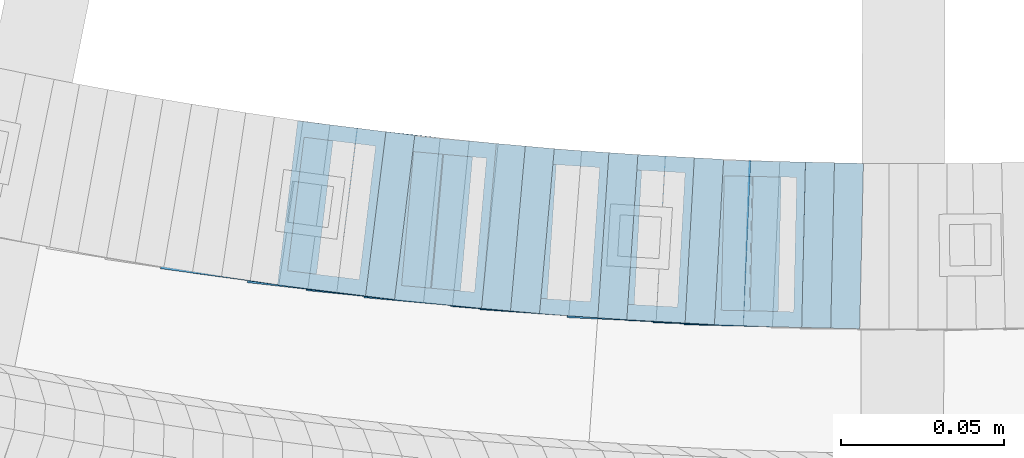
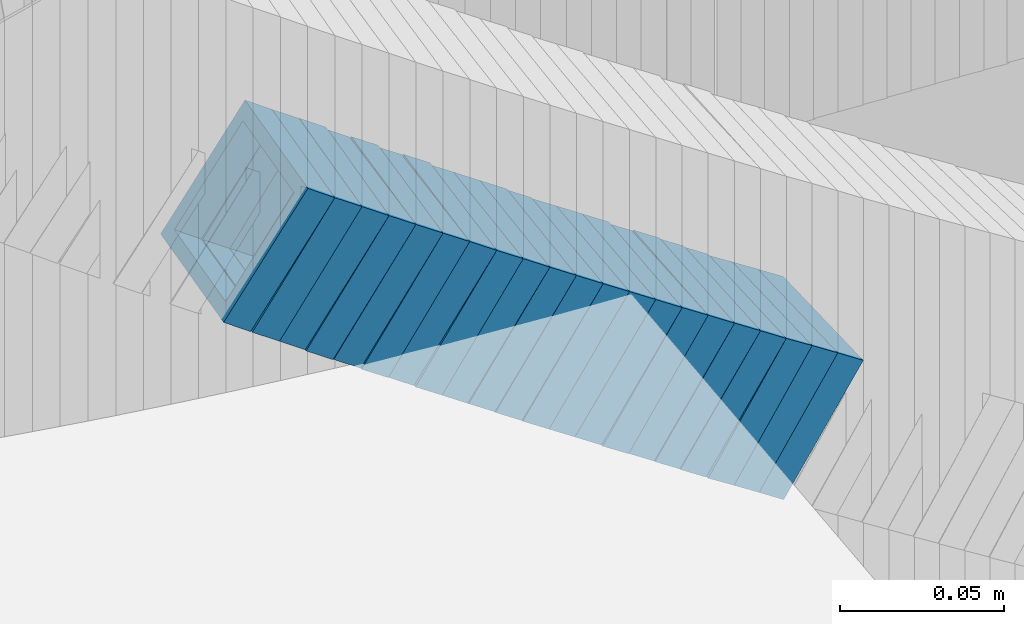
# One storey, part 697 of 975: 21 members.
"""IFC2X3 building model written with IfcOpenShell, lengths in millimetres."""

from ifc_helpers import new_model, si_unit, frame, origin_with_axes, place, context, subcontext, project, spatial, faceted_brep, material, type_object, element, save


model = new_model("IFC2X3")

# Units and contexts
model_context = context("Model", 3, precision=1e-05, world=origin_with_axes())
body_context = subcontext(model_context, "Body", "Model", "MODEL_VIEW")
ifc_project = project(units=[si_unit("LENGTHUNIT", "METRE", prefix="MILLI"), si_unit("AREAUNIT", "SQUARE_METRE"), si_unit("VOLUMEUNIT", "CUBIC_METRE"), si_unit("MASSUNIT", "GRAM", prefix="KILO"), si_unit("TIMEUNIT", "SECOND"), si_unit("PLANEANGLEUNIT", "RADIAN"), si_unit("SOLIDANGLEUNIT", "STERADIAN"), si_unit("THERMODYNAMICTEMPERATUREUNIT", "DEGREE_CELSIUS"), si_unit("LUMINOUSINTENSITYUNIT", "LUMEN")], contexts=[model_context])

# Site, building, storey
site_placement = place(None, origin_with_axes())
site = spatial("IfcSite", under=ifc_project, at=site_placement, CompositionType="ELEMENT")
building_placement = place(site_placement, origin_with_axes())
building = spatial("IfcBuilding", under=site, at=building_placement, Name="Undefined", CompositionType="ELEMENT")
storey_placement = place(building_placement, origin_with_axes())
storey = spatial("IfcBuildingStorey", under=building, at=storey_placement, Name="Undefined", CompositionType="ELEMENT", Elevation=0.0)

# Members
ifc_material = material()
member_type = type_object("IfcMemberType", Name="HSS2X2X.188_TUBES", PredefinedType="NOTDEFINED")
member_1_placement = place(storey_placement, frame((34527.8362299928, 2021.71749901124, 3420.03319222136), z_axis=(-0.135113205037553, -0.990830168002812, 2.40493136516307e-11), x_axis=(-0.829598217635618, 0.113127029950324, 0.54678064375984)))
element("IfcMember", 1, at=member_1_placement, inside=storey, type_object=member_type, material=ifc_material, Name="WALL", ObjectType="HSS2X2X.188_TUBES", context=body_context, shape_type="Brep", body=[
    faceted_brep([(0.0, 20.6374999999753, -20.6375000000298), (0.0, -20.6375000000153, -20.6375000000153), (10.6061303028146, -20.6374999999571, -20.6374999999643), (10.6061303027491, 20.6374999999971, -20.6375000000007), (0.0, -20.6374999999825, 20.6375000000335), (10.6061303027855, -20.6374999999825, 20.6375000000116), (0.0, 20.6375000000116, 20.6375000000189), (10.6061303027236, 20.637499999968, 20.6374999999716), (0.0, 25.3999999999724, -25.4000000000342), (0.0, 25.400000000016, 25.4000000000196), (10.6061303027163, 25.3999999999651, 25.3999999999651), (10.6061303027454, 25.3999999999942, -25.4000000000051), (0.0, -25.399999999976, 25.4000000000378), (10.6061303027891, -25.3999999999796, 25.4000000000124), (0.0, -25.400000000016, -25.4000000000196), (10.6061303028182, -25.3999999999505, -25.3999999999542)], [[[0, 1, 2, 3]], [[1, 4, 5, 2]], [[4, 6, 7, 5]], [[6, 0, 3, 7]], [[8, 9, 10, 11]], [[9, 12, 13, 10]], [[12, 14, 15, 13]], [[14, 8, 11, 15]], [[13, 15, 11, 10], [5, 7, 3, 2]], [[14, 12, 9, 8], [6, 4, 1, 0]]]),
])
member_2_placement = place(storey_placement, frame((34536.9699719563, 2020.46492816908, 3414.1549128678), z_axis=(-0.13362233572788, -0.991032326109813, -1.80478764377767e-10), x_axis=(-0.836723409209226, 0.112816639028211, 0.535879037134005)))
element("IfcMember", 2, at=member_2_placement, inside=storey, type_object=member_type, material=ifc_material, Name="WALL", ObjectType="HSS2X2X.188_TUBES", context=body_context, shape_type="Brep", body=[
    faceted_brep([(0.0, 20.6374999999753, -20.6375000000298), (0.0, -20.6375000000153, -20.6375000000153), (10.6395488625676, -20.6374999999771, -20.6374999999716), (10.6395488625531, 20.6374999999916, -20.6375000000189), (0.0, -20.6374999999825, 20.6375000000335), (10.6395488625731, -20.6374999999844, 20.6375000000153), (0.0, 20.6375000000116, 20.6375000000189), (10.6395488625585, 20.6374999999825, 20.637499999968), (0.0, 25.3999999999724, -25.4000000000342), (0.0, 25.400000000016, 25.4000000000196), (10.6395488625567, 25.3999999999778, 25.3999999999614), (10.6395488625494, 25.3999999999887, -25.4000000000233), (0.0, -25.399999999976, 25.4000000000378), (10.6395488625749, -25.3999999999851, 25.400000000016), (0.0, -25.400000000016, -25.4000000000196), (10.6395488625658, -25.399999999976, -25.3999999999687)], [[[0, 1, 2, 3]], [[1, 4, 5, 2]], [[4, 6, 7, 5]], [[6, 0, 3, 7]], [[8, 9, 10, 11]], [[9, 12, 13, 10]], [[12, 14, 15, 13]], [[14, 8, 11, 15]], [[13, 15, 11, 10], [5, 7, 3, 2]], [[14, 12, 9, 8], [6, 4, 1, 0]]]),
])
member_3_placement = place(storey_placement, frame((34545.7038437453, 2019.29464259044, 3408.52367431757), z_axis=(-0.135113205037553, -0.990830168002812, 2.40493136516307e-11), x_axis=(-0.833870408870343, 0.113709600982311, 0.540120604916023)))
element("IfcMember", 3, at=member_3_placement, inside=storey, type_object=member_type, material=ifc_material, Name="WALL", ObjectType="HSS2X2X.188_TUBES", context=body_context, shape_type="Brep", body=[
    faceted_brep([(0.0, 20.6374999999753, -20.6375000000298), (0.0, -20.6375000000153, -20.6375000000153), (10.5531985672587, -20.6374999999916, -20.6375000000007), (10.5531985672878, 20.6375000000062, -20.6374999999789), (0.0, -20.6374999999825, 20.6375000000335), (10.5531985672114, -20.6375000000353, 20.6374999999171), (0.0, 20.6375000000116, 20.6375000000189), (10.5531985672333, 20.6374999999607, 20.6374999999316), (0.0, 25.3999999999724, -25.4000000000342), (0.0, 25.400000000016, 25.4000000000196), (10.5531985672314, 25.399999999956, 25.3999999999251), (10.5531985672933, 25.4000000000106, -25.3999999999724), (0.0, -25.399999999976, 25.4000000000378), (10.5531985672023, -25.4000000000397, 25.3999999999069), (0.0, -25.400000000016, -25.4000000000196), (10.5531985672642, -25.3999999999851, -25.3999999999869)], [[[0, 1, 2, 3]], [[1, 4, 5, 2]], [[4, 6, 7, 5]], [[6, 0, 3, 7]], [[8, 9, 10, 11]], [[9, 12, 13, 10]], [[12, 14, 15, 13]], [[14, 8, 11, 15]], [[13, 15, 11, 10], [5, 7, 3, 2]], [[14, 12, 9, 8], [6, 4, 1, 0]]]),
])
member_4_placement = place(storey_placement, frame((34553.8807849376, 2018.05673150477, 3402.78028193762), z_axis=(-0.111656945505041, -0.993746812080665, 3.19190348818665e-10), x_axis=(-0.834110309864538, 0.0937202599847766, 0.543577504911738)))
element("IfcMember", 4, at=member_4_placement, inside=storey, type_object=member_type, material=ifc_material, Name="WALL", ObjectType="HSS2X2X.188_TUBES", context=body_context, shape_type="Brep", body=[
    faceted_brep([(0.0, 20.6374999999753, -20.6375000000298), (0.0, -20.6375000000153, -20.6375000000153), (10.6709887076922, -20.6374999999844, -20.6374999999825), (10.6709887076995, 20.6375000000171, -20.6374999999753), (0.0, -20.6374999999825, 20.6375000000335), (10.6709887076922, -20.6374999999971, 20.6375000000153), (0.0, 20.6375000000116, 20.6375000000189), (10.6709887076941, 20.6375000000025, 20.6375000000189), (0.0, 25.3999999999724, -25.4000000000342), (0.0, 25.400000000016, 25.4000000000196), (10.6709887076959, 25.3999999999996, 25.4000000000233), (10.6709887077013, 25.4000000000178, -25.3999999999724), (0.0, -25.399999999976, 25.4000000000378), (10.6709887076904, -25.3999999999978, 25.400000000016), (0.0, -25.400000000016, -25.4000000000196), (10.6709887076959, -25.3999999999796, -25.3999999999796)], [[[0, 1, 2, 3]], [[1, 4, 5, 2]], [[4, 6, 7, 5]], [[6, 0, 3, 7]], [[8, 9, 10, 11]], [[9, 12, 13, 10]], [[12, 14, 15, 13]], [[14, 8, 11, 15]], [[13, 15, 11, 10], [5, 7, 3, 2]], [[14, 12, 9, 8], [6, 4, 1, 0]]]),
])
member_5_placement = place(storey_placement, frame((34563.2585564237, 2017.05341580909, 3396.96371378049), z_axis=(-0.122662172272845, -0.992448483042474, 1.68804945133161e-10), x_axis=(-0.837575186904513, 0.1035205289882, 0.536424557938835)))
element("IfcMember", 5, at=member_5_placement, inside=storey, type_object=member_type, material=ifc_material, Name="WALL", ObjectType="HSS2X2X.188_TUBES", context=body_context, shape_type="Brep", body=[
    faceted_brep([(0.0, 20.6374999999753, -20.6375000000298), (0.0, -20.6375000000153, -20.6375000000153), (10.6348483769107, -20.637499999988, -20.6374999999825), (10.6348483768415, 20.6374999999734, -20.6375000001026), (0.0, -20.6374999999825, 20.6375000000335), (10.6348483769852, -20.6374999999589, 20.6375000001462), (0.0, 20.6375000000116, 20.6375000000189), (10.6348483769161, 20.6375000000044, 20.6375000000226), (0.0, 25.3999999999724, -25.4000000000342), (0.0, 25.400000000016, 25.4000000000196), (10.6348483769179, 25.4000000000015, 25.4000000000233), (10.6348483768288, 25.3999999999669, -25.4000000001324), (0.0, -25.399999999976, 25.4000000000378), (10.6348483769998, -25.3999999999505, 25.4000000001688), (0.0, -25.400000000016, -25.4000000000196), (10.6348483769107, -25.3999999999887, -25.3999999999833)], [[[0, 1, 2, 3]], [[1, 4, 5, 2]], [[4, 6, 7, 5]], [[6, 0, 3, 7]], [[8, 9, 10, 11]], [[9, 12, 13, 10]], [[12, 14, 15, 13]], [[14, 8, 11, 15]], [[13, 15, 11, 10], [5, 7, 3, 2]], [[14, 12, 9, 8], [6, 4, 1, 0]]]),
])
member_6_placement = place(storey_placement, frame((34571.5406122619, 2015.91831835059, 3391.27911411282), z_axis=(-0.10061048354704, -0.99492589201429, 3.4588856578921e-10), x_axis=(-0.839062756003461, 0.0848490430003576, 0.537377271002226)))
element("IfcMember", 6, at=member_6_placement, inside=storey, type_object=member_type, material=ifc_material, Name="WALL", ObjectType="HSS2X2X.188_TUBES", context=body_context, shape_type="Brep", body=[
    faceted_brep([(0.0, 20.6374999999753, -20.6375000000298), (0.0, -20.6375000000153, -20.6375000000153), (10.6061303028146, -20.6374999999571, -20.6374999999643), (10.6061303027491, 20.6374999999971, -20.6375000000007), (0.0, -20.6374999999825, 20.6375000000335), (10.6061303027855, -20.6374999999825, 20.6375000000116), (0.0, 20.6375000000116, 20.6375000000189), (10.6061303027236, 20.637499999968, 20.6374999999716), (0.0, 25.3999999999724, -25.4000000000342), (0.0, 25.400000000016, 25.4000000000196), (10.6061303027163, 25.3999999999651, 25.3999999999651), (10.6061303027454, 25.3999999999942, -25.4000000000051), (0.0, -25.399999999976, 25.4000000000378), (10.6061303027891, -25.3999999999796, 25.4000000000124), (0.0, -25.400000000016, -25.4000000000196), (10.6061303028182, -25.3999999999505, -25.3999999999542)], [[[0, 1, 2, 3]], [[1, 4, 5, 2]], [[4, 6, 7, 5]], [[6, 0, 3, 7]], [[8, 9, 10, 11]], [[9, 12, 13, 10]], [[12, 14, 15, 13]], [[14, 8, 11, 15]], [[13, 15, 11, 10], [5, 7, 3, 2]], [[14, 12, 9, 8], [6, 4, 1, 0]]]),
])
member_7_placement = place(storey_placement, frame((34580.5807849376, 2015.05673150477, 3385.58028193762), z_axis=(-0.111656945505041, -0.993746812080665, 3.19190348818665e-10), x_axis=(-0.834110309864538, 0.0937202599847766, 0.543577504911738)))
element("IfcMember", 7, at=member_7_placement, inside=storey, type_object=member_type, material=ifc_material, Name="WALL", ObjectType="HSS2X2X.188_TUBES", context=body_context, shape_type="Brep", body=[
    faceted_brep([(0.0, 20.6374999999753, -20.6375000000298), (0.0, -20.6375000000153, -20.6375000000153), (10.6709887076922, -20.6374999999844, -20.6374999999825), (10.6709887076995, 20.6375000000171, -20.6374999999753), (0.0, -20.6374999999825, 20.6375000000335), (10.6709887076922, -20.6374999999971, 20.6375000000153), (0.0, 20.6375000000116, 20.6375000000189), (10.6709887076941, 20.6375000000025, 20.6375000000189), (0.0, 25.3999999999724, -25.4000000000342), (0.0, 25.400000000016, 25.4000000000196), (10.6709887076959, 25.3999999999996, 25.4000000000233), (10.6709887077013, 25.4000000000178, -25.3999999999724), (0.0, -25.399999999976, 25.4000000000378), (10.6709887076904, -25.3999999999978, 25.400000000016), (0.0, -25.400000000016, -25.4000000000196), (10.6709887076959, -25.3999999999796, -25.3999999999796)], [[[0, 1, 2, 3]], [[1, 4, 5, 2]], [[4, 6, 7, 5]], [[6, 0, 3, 7]], [[8, 9, 10, 11]], [[9, 12, 13, 10]], [[12, 14, 15, 13]], [[14, 8, 11, 15]], [[13, 15, 11, 10], [5, 7, 3, 2]], [[14, 12, 9, 8], [6, 4, 1, 0]]]),
])
member_8_placement = place(storey_placement, frame((34589.0343534052, 2013.99484235009, 3379.7856958392), z_axis=(-0.0895266898351619, -0.99598442347617, -1.31917659018654e-10), x_axis=(-0.839697377603009, 0.0754784159643202, 0.537783713745728)))
element("IfcMember", 8, at=member_8_placement, inside=storey, type_object=member_type, material=ifc_material, Name="WALL", ObjectType="HSS2X2X.188_TUBES", context=body_context, shape_type="Brep", body=[
    faceted_brep([(0.0, 20.6374999999753, -20.6375000000298), (0.0, -20.6375000000153, -20.6375000000153), (10.6004716875832, -20.6375000000153, -20.6375000000553), (10.6004716875814, 20.6374999999898, -20.6375000000444), (0.0, -20.6374999999825, 20.6375000000335), (10.6004716876068, -20.6375000000044, 20.6374999999862), (0.0, 20.6375000000116, 20.6375000000189), (10.6004716876032, 20.6374999999989, 20.6374999999971), (0.0, 25.3999999999724, -25.4000000000342), (0.0, 25.400000000016, 25.4000000000196), (10.600471687605, 25.4000000000015, 25.4000000000051), (10.6004716875814, 25.3999999999869, -25.4000000000487), (0.0, -25.399999999976, 25.4000000000378), (10.6004716876068, -25.4000000000015, 25.3999999999905), (0.0, -25.400000000016, -25.4000000000196), (10.6004716875814, -25.4000000000178, -25.4000000000669)], [[[0, 1, 2, 3]], [[1, 4, 5, 2]], [[4, 6, 7, 5]], [[6, 0, 3, 7]], [[8, 9, 10, 11]], [[9, 12, 13, 10]], [[12, 14, 15, 13]], [[14, 8, 11, 15]], [[13, 15, 11, 10], [5, 7, 3, 2]], [[14, 12, 9, 8], [6, 4, 1, 0]]]),
])
member_9_placement = place(storey_placement, frame((34597.7659889615, 2013.20997623267, 3374.0944682119), z_axis=(-0.0895266898351619, -0.99598442347617, -1.31917659018654e-10), x_axis=(-0.835432196861874, 0.0750950289875907, 0.544438959910012)))
element("IfcMember", 9, at=member_9_placement, inside=storey, type_object=member_type, material=ifc_material, Name="WALL", ObjectType="HSS2X2X.188_TUBES", context=body_context, shape_type="Brep", body=[
    faceted_brep([(0.0, 20.6374999999753, -20.6375000000298), (0.0, -20.6375000000153, -20.6375000000153), (10.648004507897, -20.6374999999862, -20.637499999968), (10.6480045078188, 20.6374999999771, -20.6375000000808), (0.0, -20.6374999999825, 20.6375000000335), (10.6480045079406, -20.6374999999698, 20.6375000001062), (0.0, 20.6375000000116, 20.6375000000189), (10.6480045078679, 20.6374999999935, 20.6375000000007), (0.0, 25.3999999999724, -25.4000000000342), (0.0, 25.400000000016, 25.4000000000196), (10.6480045078661, 25.3999999999905, 25.4000000000015), (10.648004507806, 25.3999999999705, -25.4000000000997), (0.0, -25.399999999976, 25.4000000000378), (10.6480045079552, -25.3999999999633, 25.4000000001288), (0.0, -25.400000000016, -25.4000000000196), (10.6480045078988, -25.3999999999814, -25.3999999999651)], [[[0, 1, 2, 3]], [[1, 4, 5, 2]], [[4, 6, 7, 5]], [[6, 0, 3, 7]], [[8, 9, 10, 11]], [[9, 12, 13, 10]], [[12, 14, 15, 13]], [[14, 8, 11, 15]], [[13, 15, 11, 10], [5, 7, 3, 2]], [[14, 12, 9, 8], [6, 4, 1, 0]]]),
])
member_10_placement = place(storey_placement, frame((34606.8343534052, 2012.39484235009, 3368.2856958392), z_axis=(-0.0895266898351619, -0.99598442347617, -1.31917659018654e-10), x_axis=(-0.839697377603009, 0.0754784159643202, 0.537783713745728)))
element("IfcMember", 10, at=member_10_placement, inside=storey, type_object=member_type, material=ifc_material, Name="WALL", ObjectType="HSS2X2X.188_TUBES", context=body_context, shape_type="Brep", body=[
    faceted_brep([(0.0, 20.6374999999753, -20.6375000000298), (0.0, -20.6375000000153, -20.6375000000153), (10.6004716875832, -20.6375000000153, -20.6375000000553), (10.6004716875814, 20.6374999999898, -20.6375000000444), (0.0, -20.6374999999825, 20.6375000000335), (10.6004716876068, -20.6375000000044, 20.6374999999862), (0.0, 20.6375000000116, 20.6375000000189), (10.6004716876032, 20.6374999999989, 20.6374999999971), (0.0, 25.3999999999724, -25.4000000000342), (0.0, 25.400000000016, 25.4000000000196), (10.600471687605, 25.4000000000015, 25.4000000000051), (10.6004716875814, 25.3999999999869, -25.4000000000487), (0.0, -25.399999999976, 25.4000000000378), (10.6004716876068, -25.4000000000015, 25.3999999999905), (0.0, -25.400000000016, -25.4000000000196), (10.6004716875814, -25.4000000000178, -25.4000000000669)], [[[0, 1, 2, 3]], [[1, 4, 5, 2]], [[4, 6, 7, 5]], [[6, 0, 3, 7]], [[8, 9, 10, 11]], [[9, 12, 13, 10]], [[12, 14, 15, 13]], [[14, 8, 11, 15]], [[13, 15, 11, 10], [5, 7, 3, 2]], [[14, 12, 9, 8], [6, 4, 1, 0]]]),
])
member_11_placement = place(storey_placement, frame((34615.4462759016, 2011.56211524903, 3362.53063470783), z_axis=(-0.0775435859492209, -0.996988962967061, -3.08868948195595e-11), x_axis=(-0.838780368196513, 0.0652384730152902, 0.540547348126651)))
element("IfcMember", 11, at=member_11_placement, inside=storey, type_object=member_type, material=ifc_material, Name="WALL", ObjectType="HSS2X2X.188_TUBES", context=body_context, shape_type="Brep", body=[
    faceted_brep([(0.0, 20.6374999999753, -20.6375000000298), (0.0, -20.6375000000153, -20.6375000000153), (10.7284668056709, -20.6374999999935, -20.6374999999971), (10.7284668057473, 20.6375000000553, -20.6374999999907), (0.0, -20.6374999999825, 20.6375000000335), (10.7284668055872, -20.6375000000444, 20.6374999999907), (0.0, 20.6375000000116, 20.6375000000189), (10.7284668056673, 20.6375000000044, 20.6374999999971), (0.0, 25.3999999999724, -25.4000000000342), (0.0, 25.400000000016, 25.4000000000196), (10.7284668056673, 25.4000000000051, 25.3999999999969), (10.7284668057691, 25.4000000000706, -25.3999999999878), (0.0, -25.399999999976, 25.4000000000378), (10.728466805569, -25.4000000000524, 25.3999999999887), (0.0, -25.400000000016, -25.4000000000196), (10.7284668056709, -25.3999999999905, -25.399999999996)], [[[0, 1, 2, 3]], [[1, 4, 5, 2]], [[4, 6, 7, 5]], [[6, 0, 3, 7]], [[8, 9, 10, 11]], [[9, 12, 13, 10]], [[12, 14, 15, 13]], [[14, 8, 11, 15]], [[13, 15, 11, 10], [5, 7, 3, 2]], [[14, 12, 9, 8], [6, 4, 1, 0]]]),
])
for number, where, z_axis, x_axis, name in (
    (12, (34624.127924659, 2010.83634642639, 3356.79658430275), (-0.0672630522607651, -0.997735276413822, 1.4846455087536e-10), (-0.840745783012367, 0.0566794910008438, 0.538455164007931), "WALL"),
    (13, (34633.027924659, 2010.23634642639, 3351.09658430275), (-0.0672630522607651, -0.997735276413822, 1.4846455087536e-10), (-0.840745783012367, 0.0566794910008438, 0.538455164007931), "WALL"),
):
    element("IfcMember", number, at=place(storey_placement, frame(where, z_axis=z_axis, x_axis=x_axis)), inside=storey, type_object=member_type, material=ifc_material, Name=name, ObjectType="HSS2X2X.188_TUBES", context=body_context, shape_type="Brep", body=[
        faceted_brep([(0.0, 20.6374999999753, -20.6375000000298), (0.0, -20.6375000000153, -20.6375000000153), (10.5948100501191, -20.6375000000335, -20.6375000000844), (10.5948100501555, 20.6374999999971, -20.6375000000116), (0.0, -20.6374999999825, 20.6375000000335), (10.5948100501446, -20.6375000000098, 20.6374999999571), (0.0, 20.6375000000116, 20.6375000000189), (10.5948100501828, 20.6375000000189, 20.6375000000298), (0.0, 25.3999999999724, -25.4000000000342), (0.0, 25.400000000016, 25.4000000000196), (10.5948100501919, 25.4000000000251, 25.4000000000451), (10.5948100501591, 25.3999999999978, -25.4000000000051), (0.0, -25.399999999976, 25.4000000000378), (10.5948100501482, -25.4000000000106, 25.3999999999578), (0.0, -25.400000000016, -25.4000000000196), (10.5948100501118, -25.4000000000378, -25.400000000096)], [[[0, 1, 2, 3]], [[1, 4, 5, 2]], [[4, 6, 7, 5]], [[6, 0, 3, 7]], [[8, 9, 10, 11]], [[9, 12, 13, 10]], [[12, 14, 15, 13]], [[14, 8, 11, 15]], [[13, 15, 11, 10], [5, 7, 3, 2]], [[14, 12, 9, 8], [6, 4, 1, 0]]]),
    ])
member_12_placement = place(storey_placement, frame((34641.9475790012, 2009.63148831819, 3345.33562136469), z_axis=(-0.0665190102688867, -0.997785157873601, -4.63666765426751e-10), x_axis=(-0.839254327216278, 0.0559502880144122, 0.54085278913939)))
element("IfcMember", 14, at=member_12_placement, inside=storey, type_object=member_type, material=ifc_material, Name="WALL", ObjectType="HSS2X2X.188_TUBES", context=body_context, shape_type="Brep", body=[
    faceted_brep([(0.0, 20.6374999999753, -20.6375000000298), (0.0, -20.6375000000153, -20.6375000000153), (10.7247377590011, -20.6375000000189, -20.6375000000589), (10.7247377589938, 20.6374999999844, -20.6375000000698), (0.0, -20.6374999999825, 20.6375000000335), (10.7247377590484, -20.6374999999771, 20.6375000000517), (0.0, 20.6375000000116, 20.6375000000189), (10.7247377590447, 20.6375000000262, 20.6375000000407), (0.0, 25.3999999999724, -25.4000000000342), (0.0, 25.400000000016, 25.4000000000196), (10.7247377590484, 25.4000000000342, 25.400000000056), (10.7247377589902, 25.3999999999778, -25.4000000000851), (0.0, -25.399999999976, 25.4000000000378), (10.7247377590556, -25.3999999999724, 25.4000000000633), (0.0, -25.400000000016, -25.4000000000196), (10.7247377589938, -25.4000000000251, -25.4000000000742)], [[[0, 1, 2, 3]], [[1, 4, 5, 2]], [[4, 6, 7, 5]], [[6, 0, 3, 7]], [[8, 9, 10, 11]], [[9, 12, 13, 10]], [[12, 14, 15, 13]], [[14, 8, 11, 15]], [[13, 15, 11, 10], [5, 7, 3, 2]], [[14, 12, 9, 8], [6, 4, 1, 0]]]),
])
member_13_placement = place(storey_placement, frame((34650.3304742472, 2008.962929907, 3339.60439856372), z_axis=(-0.044898496675909, -0.998991554016471, -2.07617631531321e-10), x_axis=(-0.841497052206438, 0.0378200920092716, 0.538936315132211)))
element("IfcMember", 15, at=member_13_placement, inside=storey, type_object=member_type, material=ifc_material, Name="WALL", ObjectType="HSS2X2X.188_TUBES", context=body_context, shape_type="Brep", body=[
    faceted_brep([(0.0, 20.6374999999753, -20.6375000000298), (0.0, -20.6375000000153, -20.6375000000153), (10.5806427026419, -20.6374999999607, -20.6374999999316), (10.5806427026473, 20.6375000000444, -20.6374999999207), (0.0, -20.6374999999825, 20.6375000000335), (10.5806427025509, -20.6375000000207, 20.6374999999643), (0.0, 20.6375000000116, 20.6375000000189), (10.5806427025545, 20.6374999999862, 20.6374999999716), (0.0, 25.3999999999724, -25.4000000000342), (0.0, 25.400000000016, 25.4000000000196), (10.5806427025436, 25.3999999999796, 25.3999999999614), (10.5806427026582, 25.4000000000542, -25.3999999999105), (0.0, -25.399999999976, 25.4000000000378), (10.5806427025418, -25.4000000000287, 25.3999999999542), (0.0, -25.400000000016, -25.4000000000196), (10.5806427026528, -25.3999999999542, -25.3999999999178)], [[[0, 1, 2, 3]], [[1, 4, 5, 2]], [[4, 6, 7, 5]], [[6, 0, 3, 7]], [[8, 9, 10, 11]], [[9, 12, 13, 10]], [[12, 14, 15, 13]], [[14, 8, 11, 15]], [[13, 15, 11, 10], [5, 7, 3, 2]], [[14, 12, 9, 8], [6, 4, 1, 0]]]),
])
member_14_placement = place(storey_placement, frame((34659.5510942479, 2008.59721570047, 3333.83985056992), z_axis=(-0.0554700193634271, -0.998460353219807, -4.1682005758048e-10), x_axis=(-0.839655998186828, 0.0466475550103697, 0.541111643120379)))
element("IfcMember", 16, at=member_14_placement, inside=storey, type_object=member_type, material=ifc_material, Name="WALL", ObjectType="HSS2X2X.188_TUBES", context=body_context, shape_type="Brep", body=[
    faceted_brep([(0.0, 20.6374999999753, -20.6375000000298), (0.0, -20.6375000000153, -20.6375000000153), (10.7247377590011, -20.6375000000189, -20.6375000000589), (10.7247377589938, 20.6374999999844, -20.6375000000698), (0.0, -20.6374999999825, 20.6375000000335), (10.7247377590484, -20.6374999999771, 20.6375000000517), (0.0, 20.6375000000116, 20.6375000000189), (10.7247377590447, 20.6375000000262, 20.6375000000407), (0.0, 25.3999999999724, -25.4000000000342), (0.0, 25.400000000016, 25.4000000000196), (10.7247377590484, 25.4000000000342, 25.400000000056), (10.7247377589902, 25.3999999999778, -25.4000000000851), (0.0, -25.399999999976, 25.4000000000378), (10.7247377590556, -25.3999999999724, 25.4000000000633), (0.0, -25.400000000016, -25.4000000000196), (10.7247377589938, -25.4000000000251, -25.4000000000742)], [[[0, 1, 2, 3]], [[1, 4, 5, 2]], [[4, 6, 7, 5]], [[6, 0, 3, 7]], [[8, 9, 10, 11]], [[9, 12, 13, 10]], [[12, 14, 15, 13]], [[14, 8, 11, 15]], [[13, 15, 11, 10], [5, 7, 3, 2]], [[14, 12, 9, 8], [6, 4, 1, 0]]]),
])
member_15_placement = place(storey_placement, frame((34668.2304742472, 2008.062929907, 3328.10439856373), z_axis=(-0.044898496675909, -0.998991554016471, -2.07617631531321e-10), x_axis=(-0.841497052206438, 0.0378200920092716, 0.538936315132211)))
element("IfcMember", 17, at=member_15_placement, inside=storey, type_object=member_type, material=ifc_material, Name="WALL", ObjectType="HSS2X2X.188_TUBES", context=body_context, shape_type="Brep", body=[
    faceted_brep([(0.0, 20.6374999999753, -20.6375000000298), (0.0, -20.6375000000153, -20.6375000000153), (10.5806427026419, -20.6374999999607, -20.6374999999316), (10.5806427026473, 20.6375000000444, -20.6374999999207), (0.0, -20.6374999999825, 20.6375000000335), (10.5806427025509, -20.6375000000207, 20.6374999999643), (0.0, 20.6375000000116, 20.6375000000189), (10.5806427025545, 20.6374999999862, 20.6374999999716), (0.0, 25.3999999999724, -25.4000000000342), (0.0, 25.400000000016, 25.4000000000196), (10.5806427025436, 25.3999999999796, 25.3999999999614), (10.5806427026582, 25.4000000000542, -25.3999999999105), (0.0, -25.399999999976, 25.4000000000378), (10.5806427025418, -25.4000000000287, 25.3999999999542), (0.0, -25.400000000016, -25.4000000000196), (10.5806427026528, -25.3999999999542, -25.3999999999178)], [[[0, 1, 2, 3]], [[1, 4, 5, 2]], [[4, 6, 7, 5]], [[6, 0, 3, 7]], [[8, 9, 10, 11]], [[9, 12, 13, 10]], [[12, 14, 15, 13]], [[14, 8, 11, 15]], [[13, 15, 11, 10], [5, 7, 3, 2]], [[14, 12, 9, 8], [6, 4, 1, 0]]]),
])
member_16_placement = place(storey_placement, frame((34676.6664120575, 2007.62651801253, 3322.41633481282), z_axis=(-0.0336887321943577, -0.999432373561682, 1.36134076456074e-10), x_axis=(-0.837463937827158, 0.0282291219941647, 0.545763015887361)))
element("IfcMember", 18, at=member_16_placement, inside=storey, type_object=member_type, material=ifc_material, Name="WALL", ObjectType="HSS2X2X.188_TUBES", context=body_context, shape_type="Brep", body=[
    faceted_brep([(0.0, 20.6374999999753, -20.6375000000298), (0.0, -20.6375000000153, -20.6375000000153), (10.6348483769107, -20.637499999988, -20.6374999999825), (10.6348483768415, 20.6374999999734, -20.6375000001026), (0.0, -20.6374999999825, 20.6375000000335), (10.6348483769852, -20.6374999999589, 20.6375000001462), (0.0, 20.6375000000116, 20.6375000000189), (10.6348483769161, 20.6375000000044, 20.6375000000226), (0.0, 25.3999999999724, -25.4000000000342), (0.0, 25.400000000016, 25.4000000000196), (10.6348483769179, 25.4000000000015, 25.4000000000233), (10.6348483768288, 25.3999999999669, -25.4000000001324), (0.0, -25.399999999976, 25.4000000000378), (10.6348483769998, -25.3999999999505, 25.4000000001688), (0.0, -25.400000000016, -25.4000000000196), (10.6348483769107, -25.3999999999887, -25.3999999999833)], [[[0, 1, 2, 3]], [[1, 4, 5, 2]], [[4, 6, 7, 5]], [[6, 0, 3, 7]], [[8, 9, 10, 11]], [[9, 12, 13, 10]], [[12, 14, 15, 13]], [[14, 8, 11, 15]], [[13, 15, 11, 10], [5, 7, 3, 2]], [[14, 12, 9, 8], [6, 4, 1, 0]]]),
])
member_17_placement = place(storey_placement, frame((34685.6449606343, 2007.26953985793, 3316.5400792545), z_axis=(-0.0222167374839992, -0.999753177827191, 3.08813014271436e-10), x_axis=(-0.844670235203681, 0.0187704500045273, 0.534957815128993)))
element("IfcMember", 19, at=member_17_placement, inside=storey, type_object=member_type, material=ifc_material, Name="WALL", ObjectType="HSS2X2X.188_TUBES", context=body_context, shape_type="Brep", body=[
    faceted_brep([(0.0, 20.6374999999753, -20.6375000000298), (0.0, -20.6375000000153, -20.6375000000153), (10.6625512894789, -20.6374999999625, -20.6374999999389), (10.6625512893879, 20.6374999999789, -20.6375000000371), (0.0, -20.6374999999825, 20.6375000000335), (10.6625512894352, -20.6374999999989, 20.6375000000153), (0.0, 20.6375000000116, 20.6375000000189), (10.6625512893443, 20.6374999999443, 20.6374999999134), (0.0, 25.3999999999724, -25.4000000000342), (0.0, 25.400000000016, 25.4000000000196), (10.6625512893297, 25.3999999999342, 25.3999999998996), (10.6625512893916, 25.399999999976, -25.4000000000415), (0.0, -25.399999999976, 25.4000000000378), (10.6625512894389, -25.399999999996, 25.400000000016), (0.0, -25.400000000016, -25.4000000000196), (10.6625512894971, -25.3999999999523, -25.3999999999214)], [[[0, 1, 2, 3]], [[1, 4, 5, 2]], [[4, 6, 7, 5]], [[6, 0, 3, 7]], [[8, 9, 10, 11]], [[9, 12, 13, 10]], [[12, 14, 15, 13]], [[14, 8, 11, 15]], [[13, 15, 11, 10], [5, 7, 3, 2]], [[14, 12, 9, 8], [6, 4, 1, 0]]]),
])
member_18_placement = place(storey_placement, frame((34694.4429987294, 2007.07522383167, 3310.90910192296), z_axis=(-0.0224662378870489, -0.999747602225283, -7.55430846766103e-11), x_axis=(-0.841948781990538, 0.0189201969997969, 0.53922562499397)))
element("IfcMember", 20, at=member_18_placement, inside=storey, type_object=member_type, material=ifc_material, Name="WALL", ObjectType="HSS2X2X.188_TUBES", context=body_context, shape_type="Brep", body=[
    faceted_brep([(0.0, 20.6374999999753, -20.6375000000298), (0.0, -20.6375000000153, -20.6375000000153), (10.5744976239494, -20.6375000000207, -20.6375000000335), (10.5744976239657, 20.6375000000098, -20.637500000008), (0.0, -20.6374999999825, 20.6375000000335), (10.5744976239639, -20.6375000000244, 20.6374999999753), (0.0, 20.6375000000116, 20.6375000000189), (10.5744976239803, 20.6374999999989, 20.6374999999935), (0.0, 25.3999999999724, -25.4000000000342), (0.0, 25.400000000016, 25.4000000000196), (10.5744976239857, 25.4000000000051, 25.4000000000015), (10.5744976239675, 25.4000000000124, -25.4000000000051), (0.0, -25.399999999976, 25.4000000000378), (10.5744976239639, -25.4000000000287, 25.3999999999724), (0.0, -25.400000000016, -25.4000000000196), (10.5744976239494, -25.4000000000215, -25.4000000000378)], [[[0, 1, 2, 3]], [[1, 4, 5, 2]], [[4, 6, 7, 5]], [[6, 0, 3, 7]], [[8, 9, 10, 11]], [[9, 12, 13, 10]], [[12, 14, 15, 13]], [[14, 8, 11, 15]], [[13, 15, 11, 10], [5, 7, 3, 2]], [[14, 12, 9, 8], [6, 4, 1, 0]]]),
])
member_19_placement = place(storey_placement, frame((34703.1739221326, 2006.87902330576, 3305.2183343715), z_axis=(-0.0224662378870489, -0.999747602225283, -7.55430846766103e-11), x_axis=(-0.837649377715757, 0.0188235819936128, 0.545883863814763)))
element("IfcMember", 21, at=member_19_placement, inside=storey, type_object=member_type, material=ifc_material, Name="WALL", ObjectType="HSS2X2X.188_TUBES", context=body_context, shape_type="Brep", body=[
    faceted_brep([(0.0, 20.6374999999753, -20.6375000000298), (0.0, -20.6375000000153, -20.6375000000153), (10.6216759506497, -20.637499999968, -20.6374999999534), (10.6216759506497, 20.6375000000262, -20.6374999999643), (0.0, -20.6374999999825, 20.6375000000335), (10.6216759506169, -20.6374999999935, 20.637500000008), (0.0, 20.6375000000116, 20.6375000000189), (10.6216759506242, 20.6375000000007, 20.6374999999971), (0.0, 25.3999999999724, -25.4000000000342), (0.0, 25.400000000016, 25.4000000000196), (10.6216759506169, 25.3999999999978, 25.3999999999869), (10.6216759506533, 25.4000000000269, -25.3999999999614), (0.0, -25.399999999976, 25.4000000000378), (10.6216759506242, -25.3999999999942, 25.4000000000051), (0.0, -25.400000000016, -25.4000000000196), (10.6216759506569, -25.3999999999614, -25.3999999999432)], [[[0, 1, 2, 3]], [[1, 4, 5, 2]], [[4, 6, 7, 5]], [[6, 0, 3, 7]], [[8, 9, 10, 11]], [[9, 12, 13, 10]], [[12, 14, 15, 13]], [[14, 8, 11, 15]], [[13, 15, 11, 10], [5, 7, 3, 2]], [[14, 12, 9, 8], [6, 4, 1, 0]]]),
])

save(model, "model.ifc")
